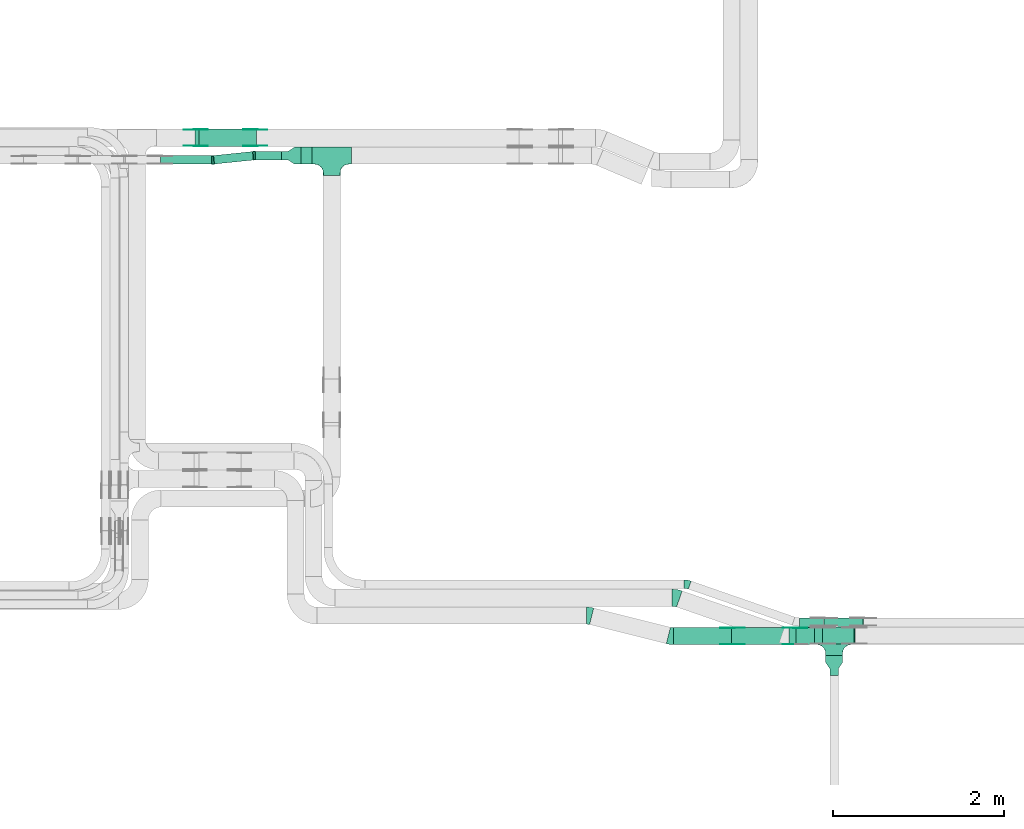
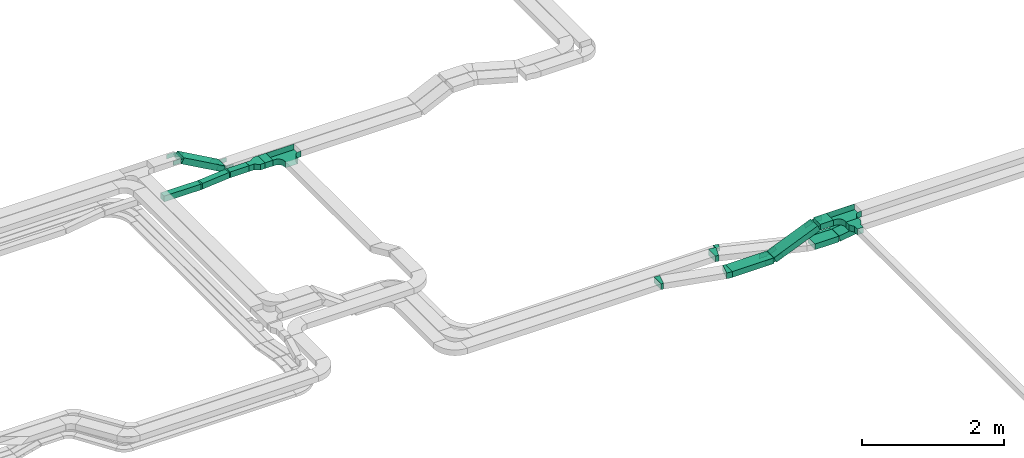
# One storey, part 13 of 23: 25 flow fittings, 12 flow segments.
"""IFC2X3 building model written with IfcOpenShell, lengths in millimetres."""

import ifcopenshell
import ifcopenshell.guid

model = None  # the IFC model being written
_history = None  # IfcOwnerHistory: only IFC2X3 demands one
_inside = {}  # id of a spatial element -> (the spatial element, [elements in it])
_under = {}  # id of a project, library or spatial element -> (it, [spatial elements below it])
_declared = {}  # id of a project -> (the project, [libraries it declares])
_typed = {}  # id of a type object -> (the type object, [elements of that type])
_made_of = {}  # id of a material, layer set ... -> (it, [elements and type objects made of it])


def new_model(schema):
    """Start an empty IFC model of exactly this schema.

    Asked for "IFC4X3", IfcOpenShell would pick the latest addendum, in which some entities
    have other attributes; the version numbers below select the first issue.
    IFC2X3 requires an IfcOwnerHistory on every rooted entity: one is made here for all.
    """
    global model, _history
    if schema == "IFC4X3":
        model = ifcopenshell.file(schema_version=(4, 3, 0, 0))
    else:
        model = ifcopenshell.file(schema=schema)
    _inside.clear()
    _under.clear()
    _declared.clear()
    _typed.clear()
    _made_of.clear()
    _history = None
    if model.schema == "IFC2X3":
        org = make("IfcOrganization", Name="unknown")
        user = make(
            "IfcPersonAndOrganization",
            ThePerson=make("IfcPerson", FamilyName="unknown"),
            TheOrganization=org,
        )
        app = make(
            "IfcApplication",
            ApplicationDeveloper=org,
            Version="unknown",
            ApplicationFullName="unknown",
            ApplicationIdentifier="unknown",
        )
        _history = make(
            "IfcOwnerHistory",
            OwningUser=user,
            OwningApplication=app,
            ChangeAction="ADDED",
            CreationDate=0,
        )
    return model


def make(cls, **values):
    """One entity of the class cls with the attributes given. An attribute that is None is left unset."""
    return model.create_entity(
        cls, **{name: value for name, value in values.items() if value is not None}
    )


def entity(cls, *values):
    """Any entity or typed value of the class cls, its attributes in the order of the schema. None: left unset."""
    e = model.create_entity(cls)
    for i, value in enumerate(values):
        if value is not None:
            e[i] = value
    return e


def rooted(cls, **values):
    """An entity with a GlobalId (a new one), such as an element, a storey or a relation."""
    return make(cls, GlobalId=ifcopenshell.guid.new(), OwnerHistory=_history, **values)


def si_unit(unit_type, name, prefix=None):
    """IfcSIUnit, for example si_unit("LENGTHUNIT", "METRE", prefix="MILLI")."""
    return make("IfcSIUnit", UnitType=unit_type, Prefix=prefix, Name=name)


def converted_unit(unit_type, name, factor, base, dimensions=None, offset=None):
    """IfcConversionBasedUnit, such as the inch: factor (a typed value) times the base unit."""
    return make(
        "IfcConversionBasedUnit"
        if offset is None
        else "IfcConversionBasedUnitWithOffset",
        ConversionOffset=offset,
        Dimensions=None
        if dimensions is None
        else entity("IfcDimensionalExponents", *dimensions),
        UnitType=unit_type,
        Name=name,
        ConversionFactor=make(
            "IfcMeasureWithUnit", ValueComponent=factor, UnitComponent=base
        ),
    )


def derived_unit(unit_type, elements):
    """IfcDerivedUnit: a product of units, each with its exponent."""
    return make(
        "IfcDerivedUnit",
        Elements=[
            make("IfcDerivedUnitElement", Unit=unit, Exponent=power)
            for unit, power in elements
        ],
        UnitType=unit_type,
    )


def assignment(units):
    """IfcUnitAssignment: the units of a project."""
    return None if units is None else make("IfcUnitAssignment", Units=units)


def point(xyz):
    """IfcCartesianPoint."""
    return None if xyz is None else make("IfcCartesianPoint", Coordinates=xyz)


def direction(xyz):
    """IfcDirection."""
    return None if xyz is None else make("IfcDirection", DirectionRatios=xyz)


def frame(location, z_axis=None, x_axis=None):
    """IfcAxis2Placement3D, a coordinate frame: its origin and axes. An axis left out is left unset."""
    return make(
        "IfcAxis2Placement3D",
        Location=point(location),
        Axis=direction(z_axis),
        RefDirection=direction(x_axis),
    )


def frame_2d(location, x_axis=None):
    """IfcAxis2Placement2D, a coordinate frame in the plane: its origin and x axis."""
    return make(
        "IfcAxis2Placement2D", Location=point(location), RefDirection=direction(x_axis)
    )


def origin():
    """The frame at (0, 0, 0) with its axes left unset."""
    return frame((0.0, 0.0, 0.0))


def origin_2d_with_axis():
    """The frame at (0, 0) in the plane with the x axis (1, 0) written out."""
    return frame_2d((0.0, 0.0), x_axis=(1.0, 0.0))


def place(relative_to, where):
    """IfcLocalPlacement: puts the frame where relative to a parent placement (None: the world)."""
    return make(
        "IfcLocalPlacement", PlacementRelTo=relative_to, RelativePlacement=where
    )


def context(
    kind, dimensions, precision=None, world=None, true_north=None, identifier=None
):
    """IfcGeometricRepresentationContext, for example the 3D "Model" context."""
    return make(
        "IfcGeometricRepresentationContext",
        ContextIdentifier=identifier,
        ContextType=kind,
        CoordinateSpaceDimension=dimensions,
        Precision=precision,
        WorldCoordinateSystem=world,
        TrueNorth=true_north,
    )


def subcontext(parent, identifier, kind, view, scale=None):
    """IfcGeometricRepresentationSubContext, for example "Body" below "Model"."""
    return make(
        "IfcGeometricRepresentationSubContext",
        ContextIdentifier=identifier,
        ContextType=kind,
        ParentContext=parent,
        TargetScale=scale,
        TargetView=view,
    )


def project(units=None, contexts=None):
    """IfcProject with its units and contexts."""
    return rooted(
        "IfcProject",
        Name="project",
        RepresentationContexts=contexts,
        UnitsInContext=assignment(units),
    )


def spatial(cls, under=None, at=None, **own):
    """A site, building, storey or space (cls), placed at a placement, below another one or the project."""
    s = rooted(cls, ObjectPlacement=at, **own)
    if under is not None:
        _under.setdefault(under.id(), (under, []))[1].append(s)
    return s


def polyline(points):
    """IfcPolyline through the points."""
    return make("IfcPolyline", Points=[point(p) for p in points])


def circle_curve(where, radius):
    """IfcCircle in the frame where."""
    return make("IfcCircle", Position=where, Radius=radius)


def parameter(value):
    """IfcParameterValue: where a trimmed curve begins or ends, as a parameter of its basis curve."""
    return model.create_entity("IfcParameterValue", value)


def trimmed(basis, trim1, trim2, sense, master):
    """IfcTrimmedCurve: the piece of a basis curve between two trims."""
    return make(
        "IfcTrimmedCurve",
        BasisCurve=basis,
        Trim1=trim1,
        Trim2=trim2,
        SenseAgreement=sense,
        MasterRepresentation=master,
    )


def segment(curve, same_sense, transition):
    """IfcCompositeCurveSegment."""
    return make(
        "IfcCompositeCurveSegment",
        Transition=transition,
        SameSense=same_sense,
        ParentCurve=curve,
    )


def composite_curve(segments, self_intersect=None):
    """IfcCompositeCurve: segments joined end to end."""
    return make("IfcCompositeCurve", Segments=segments, SelfIntersect=self_intersect)


def profile(cls, at=None, kind="AREA", **sizes):
    """A parametric profile (cls). Its sizes go by their IFC names, for example OverallWidth=200.0."""
    return make(cls, ProfileType=kind, Position=at, **sizes)


def rectangle(**sizes):
    """IfcRectangleProfileDef."""
    return profile("IfcRectangleProfileDef", **sizes)


def outline(outer, holes=None, kind="AREA"):
    """IfcArbitraryClosedProfileDef: a profile drawn as a closed curve; with holes, ...WithVoids."""
    if holes is None:
        return make("IfcArbitraryClosedProfileDef", ProfileType=kind, OuterCurve=outer)
    return make(
        "IfcArbitraryProfileDefWithVoids",
        ProfileType=kind,
        OuterCurve=outer,
        InnerCurves=holes,
    )


def extrude(swept, where, along, depth):
    """IfcExtrudedAreaSolid: the profile swept, set in the frame where, extruded along a direction by depth."""
    return make(
        "IfcExtrudedAreaSolid",
        SweptArea=swept,
        Position=where,
        ExtrudedDirection=direction(along),
        Depth=depth,
    )


def faces_of(points, faces, orient=None, outer=None):
    """IfcFace entities. A face is a list of loops; a loop is a list of indices into points, from 0.

    orient and outer hold one flag for each loop. By default every Orientation is true, the
    first loop of a face is its IfcFaceOuterBound and the others are IfcFaceBound.
    """
    made = []
    for i, loops in enumerate(faces):
        bounds = []
        for j, loop in enumerate(loops):
            is_outer = j == 0 if outer is None else outer[i][j]
            bounds.append(
                make(
                    "IfcFaceOuterBound" if is_outer else "IfcFaceBound",
                    Bound=make("IfcPolyLoop", Polygon=[points[k] for k in loop]),
                    Orientation=True if orient is None else orient[i][j],
                )
            )
        made.append(make("IfcFace", Bounds=bounds))
    return made


def faceted_brep(points, faces, orient=None, outer=None, voids=None):
    """IfcFacetedBrep: a solid bounded by flat faces; with voids (closed shells), ...WithVoids."""
    shared = [point(p) for p in points]
    hull = make("IfcClosedShell", CfsFaces=faces_of(shared, faces, orient, outer))
    if voids is None:
        return make("IfcFacetedBrep", Outer=hull)
    return make(
        "IfcFacetedBrepWithVoids",
        Outer=hull,
        Voids=[
            make(cls, CfsFaces=faces_of(shared, fs, o, b)) for cls, fs, o, b in voids
        ],
    )


def shape(context_of_items, identifier, shape_type, items):
    """IfcShapeRepresentation: the items that make up one representation, for example the "Body"."""
    return make(
        "IfcShapeRepresentation",
        ContextOfItems=context_of_items,
        RepresentationIdentifier=identifier,
        RepresentationType=shape_type,
        Items=items,
    )


def source(mapping_origin, context_of_items, identifier, shape_type, items):
    """IfcRepresentationMap: a shape defined once, which mapped items show again and again."""
    return make(
        "IfcRepresentationMap",
        MappingOrigin=mapping_origin,
        MappedRepresentation=shape(context_of_items, identifier, shape_type, items),
    )


def transform(
    local_origin,
    x_axis=None,
    y_axis=None,
    z_axis=None,
    scale=None,
    scale2=None,
    scale3=None,
    uniform=True,
):
    """IfcCartesianTransformationOperator3D, or its non-uniform kind. x_axis, y_axis, z_axis: its Axis1, 2, 3."""
    if uniform:
        return make(
            "IfcCartesianTransformationOperator3D",
            Axis1=direction(x_axis),
            Axis2=direction(y_axis),
            LocalOrigin=point(local_origin),
            Scale=scale,
            Axis3=direction(z_axis),
        )
    return make(
        "IfcCartesianTransformationOperator3DnonUniform",
        Axis1=direction(x_axis),
        Axis2=direction(y_axis),
        LocalOrigin=point(local_origin),
        Scale=scale,
        Axis3=direction(z_axis),
        Scale2=scale2,
        Scale3=scale3,
    )


def mapped(mapping_source, mapping_target):
    """IfcMappedItem: shows the shape of a source again, moved by a transform."""
    return make(
        "IfcMappedItem", MappingSource=mapping_source, MappingTarget=mapping_target
    )


def material(Name=None, Category=None):
    """IfcMaterial."""
    return make("IfcMaterial", Name=Name, Category=Category)


def made_of(thing, what):
    """Note that an element or type object is made of a material, layer set ...; save() writes the relation."""
    if what is not None:
        _made_of.setdefault(what.id(), (what, []))[1].append(thing)
    return thing


def type_object(cls, material=None, **own):
    """A type object (cls), such as IfcWallType, which elements share."""
    return made_of(rooted(cls, **own), material)


def type_shapes(of_type, sources):
    """Give a type object the sources (RepresentationMaps) that its elements show as mapped items."""
    of_type.RepresentationMaps = sources


def element(
    cls,
    number,
    at=None,
    inside=None,
    cuts=None,
    type_object=None,
    material=None,
    context=None,
    identifier="Body",
    shape_type=None,
    held_by="IfcProductDefinitionShape",
    body=None,
    shapes=None,
    **own,
):
    """One element of the class cls, such as IfcWall. Its Tag is "e" and its number.

    at: its placement. inside: the storey or other place that contains it. cuts: it is an
    opening in that element (IfcRelVoidsElement). A single representation is given by context,
    identifier, shape_type and body (its items); several are given by shapes. held_by: the class
    of the entity that holds the representations. save() writes the other relations.
    """
    e = rooted(cls, Tag="e%d" % number, ObjectPlacement=at, **own)
    if body is not None:
        shapes = [shape(context, identifier, shape_type, body)]
    if shapes is not None:
        e.Representation = make(held_by, Representations=shapes)
    if inside is not None:
        _inside.setdefault(inside.id(), (inside, []))[1].append(e)
    if cuts is not None:
        rooted(
            "IfcRelVoidsElement", RelatingBuildingElement=cuts, RelatedOpeningElement=e
        )
    if type_object is not None:
        _typed.setdefault(type_object.id(), (type_object, []))[1].append(e)
    return made_of(e, material)


def aggregate(whole, parts):
    """IfcRelAggregates: a whole, such as a stair, and the parts it consists of."""
    return rooted("IfcRelAggregates", RelatingObject=whole, RelatedObjects=parts)


def save(model, path):
    """Write the relations noted so far, then the file.

    IfcRelAggregates (storeys below a building ...), IfcRelContainedInSpatialStructure (elements
    in a storey), IfcRelDefinesByType, IfcRelAssociatesMaterial and IfcRelDeclares: one each for
    every whole, place, type object, material and project.
    """
    for whole, parts in _under.values():
        aggregate(whole, parts)
    for where, things in _inside.values():
        rooted(
            "IfcRelContainedInSpatialStructure",
            RelatedElements=things,
            RelatingStructure=where,
        )
    for kind, things in _typed.values():
        rooted("IfcRelDefinesByType", RelatedObjects=things, RelatingType=kind)
    for what, things in _made_of.values():
        rooted("IfcRelAssociatesMaterial", RelatedObjects=things, RelatingMaterial=what)
    for by, libraries in _declared.values():
        rooted("IfcRelDeclares", RelatingContext=by, RelatedDefinitions=libraries)
    model.write(path)


model = new_model("IFC2X3")

# Units and contexts
model_context = context("Model", 3, precision=0.01, world=origin(), true_north=direction((6.12303176911189e-17, 1.0)))
body_context = subcontext(model_context, "Body", "Model", "MODEL_VIEW")
ifc_project = project(units=[si_unit("LENGTHUNIT", "METRE", prefix="MILLI"), si_unit("AREAUNIT", "SQUARE_METRE"), si_unit("VOLUMEUNIT", "CUBIC_METRE"), converted_unit("PLANEANGLEUNIT", "DEGREE", entity("IfcRatioMeasure", 0.0174532925199433), si_unit("PLANEANGLEUNIT", "RADIAN"), dimensions=[0, 0, 0, 0, 0, 0, 0]), si_unit("MASSUNIT", "GRAM", prefix="KILO"), derived_unit("MASSDENSITYUNIT", [(si_unit("MASSUNIT", "GRAM", prefix="KILO"), 1), (si_unit("LENGTHUNIT", "METRE"), -3)]), derived_unit("MOMENTOFINERTIAUNIT", [(si_unit("LENGTHUNIT", "METRE"), 4)]), si_unit("TIMEUNIT", "SECOND"), si_unit("FREQUENCYUNIT", "HERTZ"), si_unit("THERMODYNAMICTEMPERATUREUNIT", "DEGREE_CELSIUS"), derived_unit("THERMALTRANSMITTANCEUNIT", [(si_unit("MASSUNIT", "GRAM", prefix="KILO"), 1), (si_unit("THERMODYNAMICTEMPERATUREUNIT", "KELVIN"), -1), (si_unit("TIMEUNIT", "SECOND"), -3)]), derived_unit("VOLUMETRICFLOWRATEUNIT", [(si_unit("LENGTHUNIT", "METRE"), 3), (si_unit("TIMEUNIT", "SECOND"), -1)]), derived_unit("MASSFLOWRATEUNIT", [(si_unit("MASSUNIT", "GRAM", prefix="KILO"), 1), (si_unit("TIMEUNIT", "SECOND"), -1)]), derived_unit("ROTATIONALFREQUENCYUNIT", [(si_unit("TIMEUNIT", "SECOND"), -1)]), si_unit("ELECTRICCURRENTUNIT", "AMPERE"), si_unit("ELECTRICVOLTAGEUNIT", "VOLT"), si_unit("POWERUNIT", "WATT"), si_unit("FORCEUNIT", "NEWTON", prefix="KILO"), si_unit("ILLUMINANCEUNIT", "LUX"), si_unit("LUMINOUSFLUXUNIT", "LUMEN"), si_unit("LUMINOUSINTENSITYUNIT", "CANDELA"), derived_unit("USERDEFINED", [(si_unit("MASSUNIT", "GRAM", prefix="KILO"), -1), (si_unit("LENGTHUNIT", "METRE"), -2), (si_unit("TIMEUNIT", "SECOND"), 3), (si_unit("LUMINOUSFLUXUNIT", "LUMEN"), 1)]), derived_unit("LINEARVELOCITYUNIT", [(si_unit("LENGTHUNIT", "METRE"), 1), (si_unit("TIMEUNIT", "SECOND"), -1)]), si_unit("PRESSUREUNIT", "PASCAL"), derived_unit("USERDEFINED", [(si_unit("LENGTHUNIT", "METRE"), -2), (si_unit("MASSUNIT", "GRAM", prefix="KILO"), 1), (si_unit("TIMEUNIT", "SECOND"), -2)]), derived_unit("LINEARFORCEUNIT", [(si_unit("MASSUNIT", "GRAM", prefix="KILO"), 1), (si_unit("LENGTHUNIT", "METRE"), 1), (si_unit("TIMEUNIT", "SECOND"), -2), (si_unit("LENGTHUNIT", "METRE"), -1)]), derived_unit("PLANARFORCEUNIT", [(si_unit("MASSUNIT", "GRAM", prefix="KILO"), 1), (si_unit("LENGTHUNIT", "METRE"), 1), (si_unit("TIMEUNIT", "SECOND"), -2), (si_unit("LENGTHUNIT", "METRE"), -2)])], contexts=[model_context])

# Site, building, storey
site_placement = place(None, origin())
site = spatial("IfcSite", under=ifc_project, at=site_placement, CompositionType="ELEMENT")
building_placement = place(site_placement, origin())
building = spatial("IfcBuilding", under=site, at=building_placement, CompositionType="ELEMENT")
storey_placement = place(building_placement, frame((0.0, 0.0, 24000.0)))
storey = spatial("IfcBuildingStorey", under=building, at=storey_placement, CompositionType="ELEMENT", Elevation=24000.0)

# Flow segments
cable_carrier_segment_type = type_object("IfcCableCarrierSegmentType", PredefinedType="CABLETRAYSEGMENT")
flow_segment_1_placement = place(storey_placement, frame((40980.88, 8734.99, 2970.0)))
element("IfcFlowSegment", 1, at=flow_segment_1_placement, inside=storey, type_object=cable_carrier_segment_type, context=body_context, shape_type="SweptSolid", body=[
    extrude(rectangle(XDim=214.228543290827, YDim=200.0, at=origin_2d_with_axis()), frame((107.11, 100.0, 0.0), z_axis=(0.0, 0.0, 1.0), x_axis=(-1.0, 0.0, 0.0)), (0.0, 0.0, 1.0), 100.000000000003),
])
flow_segment_2_placement = place(storey_placement, frame((35176.24, 14367.82, 2650.0)))
element("IfcFlowSegment", 2, at=flow_segment_2_placement, inside=storey, type_object=cable_carrier_segment_type, context=body_context, shape_type="SweptSolid", body=[
    extrude(rectangle(XDim=129.37484695584, YDim=199.999999999998, at=origin_2d_with_axis()), frame((64.69, 100.0, 0.0)), (0.0, 0.0, 1.0), 100.000000000003),
])
flow_segment_3_placement = place(storey_placement, frame((34637.54, 14417.82, 2650.0)))
element("IfcFlowSegment", 3, at=flow_segment_3_placement, inside=storey, type_object=cable_carrier_segment_type, context=body_context, shape_type="SweptSolid", body=[
    extrude(rectangle(XDim=308.701859648406, YDim=99.9999999999989, at=origin_2d_with_axis()), frame((154.35, 50.0, 0.0), z_axis=(0.0, 0.0, 1.0), x_axis=(-1.0, 0.0, 0.0)), (0.0, 0.0, 1.0), 100.000000000003),
])
flow_segment_4_placement = place(storey_placement, frame((39544.83, 8734.99, 2660.0)))
element("IfcFlowSegment", 4, at=flow_segment_4_placement, inside=storey, type_object=cable_carrier_segment_type, context=body_context, shape_type="SweptSolid", body=[
    extrude(rectangle(XDim=676.342218198149, YDim=200.0, at=origin_2d_with_axis()), frame((338.17, 100.0, 0.0)), (0.0, 0.0, 1.0), 100.000000000008),
])
flow_segment_5_placement = place(storey_placement, frame((40224.65, 8734.99, 2668.55)))
element("IfcFlowSegment", 5, at=flow_segment_5_placement, inside=storey, type_object=cable_carrier_segment_type, context=body_context, shape_type="SweptSolid", body=[
    extrude(rectangle(XDim=99.9999999999999, YDim=200.0, at=origin_2d_with_axis()), frame((19.41, 100.0, 46.08), z_axis=(0.921566974007608, 0.0, 0.388219412727468), x_axis=(-0.388219412727468, 0.0, 0.921566974007608)), (0.0, 0.0, 1.0), 774.697978791067),
])
flow_segment_6_placement = place(storey_placement, frame((40896.23, 8739.99, 2660.0)))
element("IfcFlowSegment", 6, at=flow_segment_6_placement, inside=storey, type_object=cable_carrier_segment_type, context=body_context, shape_type="SweptSolid", body=[
    extrude(rectangle(XDim=391.57439846643, YDim=200.0, at=origin_2d_with_axis()), frame((195.79, 100.0, 0.0), z_axis=(0.0, 0.0, 1.0), x_axis=(-1.0, 0.0, 0.0)), (0.0, 0.0, 1.0), 99.9999999999989),
])
flow_segment_7_placement = place(storey_placement, frame((41290.42, 8739.99, 2661.46)))
element("IfcFlowSegment", 7, at=flow_segment_7_placement, inside=storey, type_object=cable_carrier_segment_type, context=body_context, shape_type="SweptSolid", body=[
    extrude(rectangle(XDim=99.9999999999997, YDim=200.0, at=origin_2d_with_axis()), frame((7.88, 100.0, 49.37), z_axis=(0.987498754448712, 0.0, 0.157626805976146), x_axis=(-0.157626805976146, 0.0, 0.987498754448712)), (0.0, 0.0, 1.0), 370.080529813316),
])
flow_segment_8_placement = place(storey_placement, frame((41017.8, 8949.99, 2660.0)))
element("IfcFlowSegment", 8, at=flow_segment_8_placement, inside=storey, type_object=cable_carrier_segment_type, context=body_context, shape_type="SweptSolid", body=[
    extrude(rectangle(XDim=285.588978631639, YDim=99.9999999999989, at=origin_2d_with_axis()), frame((142.79, 50.0, 0.0), z_axis=(0.0, 0.0, 1.0), x_axis=(-1.0, 0.0, 0.0)), (0.0, 0.0, 1.0), 49.9999999999973),
])
flow_segment_9_placement = place(storey_placement, frame((41305.89, 8949.99, 2660.58)))
element("IfcFlowSegment", 9, at=flow_segment_9_placement, inside=storey, type_object=cable_carrier_segment_type, context=body_context, shape_type="SweptSolid", body=[
    extrude(rectangle(XDim=50.0000000000049, YDim=99.9999999999989, at=frame_2d((0.0, 0.0), x_axis=(0.0, 1.0))), frame((3.21, 50.0, 24.79), z_axis=(0.991697353687332, 0.0, 0.128593773914383), x_axis=(0.0, 1.0, 0.0)), (0.0, 0.0, 1.0), 460.840810267681),
])
flow_segment_10_placement = place(storey_placement, frame((33528.94, 14367.82, 2650.0)))
element("IfcFlowSegment", 10, at=flow_segment_10_placement, inside=storey, type_object=cable_carrier_segment_type, context=body_context, shape_type="SweptSolid", body=[
    extrude(rectangle(XDim=601.769552047414, YDim=99.9999999999989, at=origin_2d_with_axis()), frame((300.88, 50.0, 0.0)), (0.0, 0.0, 1.0), 100.000000000003),
])
flow_segment_11_placement = place(storey_placement, frame((34148.11, 14369.25, 2650.0)))
element("IfcFlowSegment", 11, at=flow_segment_11_placement, inside=storey, type_object=cable_carrier_segment_type, context=body_context, shape_type="SweptSolid", body=[
    extrude(rectangle(XDim=464.215540721123, YDim=100.000000000002, at=origin_2d_with_axis()), frame((236.02, 73.58, 0.0), z_axis=(0.0, 0.0, 1.0), x_axis=(-0.994711436792197, -0.102709091685221, 0.0)), (0.0, 0.0, 1.0), 100.000000000003),
])
flow_segment_12_placement = place(storey_placement, frame((33931.84, 14577.82, 2663.71)))
element("IfcFlowSegment", 12, at=flow_segment_12_placement, inside=storey, type_object=cable_carrier_segment_type, context=body_context, shape_type="SweptSolid", body=[
    extrude(rectangle(XDim=100.000000000003, YDim=200.000000000002, at=origin_2d_with_axis()), frame((24.4, 100.0, 418.93), z_axis=(0.872835715211419, 0.0, -0.488014153740823), x_axis=(0.488014153740823, 0.0, 0.872835715211419)), (0.0, 0.0, 1.0), 769.01505019583),
])

# Flow fittings
ifc_material_1 = material()
cable_carrier_fitting_type_1 = type_object("IfcCableCarrierFittingType", PredefinedType="NOTDEFINED", material=ifc_material_1)
shared_shape_1 = source(origin(), body_context, "Body", "SweptSolid", [
    extrude(outline(polyline([(-115.0, -100.0), (-38.33, -100.0), (38.33, -50.0), (115.0, -50.0), (115.0, 50.0), (38.33, 50.0), (-38.33, 100.0), (-115.0, 100.0), (-115.0, -100.0)])), frame((115.0, 0.0, -50.0)), (0.0, 0.0, 1.0), 100.0),
])
type_shapes(cable_carrier_fitting_type_1, [shared_shape_1])
flow_fitting_1_placement = place(storey_placement, frame((41425.11, 8604.99, 3020.0), z_axis=(0.0, 0.0, 1.0), x_axis=(0.0, -1.0, 0.0)))
element("IfcFlowFitting", 13, at=flow_fitting_1_placement, inside=storey, type_object=cable_carrier_fitting_type_1, material=ifc_material_1, Name="470_DKC_S5_adapter", context=body_context, shape_type="MappedRepresentation", body=[
    mapped(shared_shape_1, transform((0.0, 0.0, 0.0), scale=1.0)),
])
cable_carrier_fitting_type_2 = type_object("IfcCableCarrierFittingType", PredefinedType="NOTDEFINED", material=ifc_material_1)
shared_shape_2 = source(origin(), body_context, "Body", "SweptSolid", [
    extrude(outline(polyline([(-115.0, 50.0), (-115.0, -50.0), (-38.33, -50.0), (38.33, -100.0), (115.0, -100.0), (115.0, 100.0), (38.33, 100.0), (-38.33, 50.0), (-115.0, 50.0)])), frame((115.0, 0.0, -50.0), z_axis=(0.0, 0.0, -1.0), x_axis=(1.0, 0.0, 0.0)), (0.0, 0.0, -1.0), 100.0),
])
type_shapes(cable_carrier_fitting_type_2, [shared_shape_2])
flow_fitting_2_placement = place(storey_placement, frame((34946.24, 14467.82, 2700.0)))
element("IfcFlowFitting", 14, at=flow_fitting_2_placement, inside=storey, type_object=cable_carrier_fitting_type_2, material=ifc_material_1, Name="470_DKC_S5_adapter", context=body_context, shape_type="MappedRepresentation", body=[
    mapped(shared_shape_2, transform((0.0, 0.0, 0.0), scale=1.0)),
])
cable_carrier_fitting_type_3 = type_object("IfcCableCarrierFittingType", PredefinedType="NOTDEFINED", material=ifc_material_1)
shared_shape_3 = source(origin(), body_context, "Body", "Brep", [
    faceted_brep([(-103.41, -174.12, 50.0), (-100.0, -200.0, 50.0), (-100.0, -230.0, 50.0), (-99.2, -230.0, 50.0), (-99.2, -200.0, 50.0), (-102.63, -173.91, 50.0), (-112.7, -149.6, 50.0), (-128.72, -128.72, 50.0), (-149.6, -112.7, 50.0), (-173.91, -102.63, 50.0), (-200.0, -99.2, 50.0), (-230.0, -99.2, 50.0), (-230.0, -100.0, 50.0), (-200.0, -100.0, 50.0), (-174.12, -103.41, 50.0), (-150.0, -113.4, 50.0), (-129.29, -129.29, 50.0), (-113.4, -150.0, 50.0), (230.0, -100.0, 50.0), (230.0, -99.2, 50.0), (200.0, -99.2, 50.0), (173.91, -102.63, 50.0), (149.6, -112.7, 50.0), (128.72, -128.72, 50.0), (112.7, -149.6, 50.0), (102.63, -173.91, 50.0), (99.2, -200.0, 50.0), (99.2, -230.0, 50.0), (100.0, -230.0, 50.0), (100.0, -200.0, 50.0), (103.41, -174.12, 50.0), (113.4, -150.0, 50.0), (129.29, -129.29, 50.0), (150.0, -113.4, 50.0), (174.12, -103.41, 50.0), (200.0, -100.0, 50.0), (230.0, 99.2, 50.0), (230.0, 100.0, 50.0), (-230.0, 100.0, 50.0), (-230.0, 99.2, 50.0), (-230.0, -100.0, -50.0), (-230.0, 100.0, -50.0), (230.0, 100.0, -50.0), (230.0, -100.0, -50.0), (200.0, -100.0, -50.0), (174.12, -103.41, -50.0), (150.0, -113.4, -50.0), (129.29, -129.29, -50.0), (113.4, -150.0, -50.0), (103.41, -174.12, -50.0), (100.0, -200.0, -50.0), (100.0, -230.0, -50.0), (-100.0, -230.0, -50.0), (-100.0, -200.0, -50.0), (-103.41, -174.12, -50.0), (-113.4, -150.0, -50.0), (-129.29, -129.29, -50.0), (-150.0, -113.4, -50.0), (-174.12, -103.41, -50.0), (-200.0, -100.0, -50.0), (-100.0, -200.0, -49.2), (99.2, -230.0, -49.2), (-99.2, -230.0, -49.2), (-99.2, -200.0, -49.2), (-200.0, -99.2, -49.2), (-230.0, -99.2, -49.2), (230.0, -99.2, -49.2), (200.0, -99.2, -49.2), (-230.0, 99.2, -49.2), (-200.0, -100.0, -49.2), (200.0, -100.0, -49.2), (230.0, 99.2, -49.2), (99.2, -200.0, -49.2), (100.0, -200.0, -49.2), (-173.91, -102.63, -49.2), (-149.6, -112.7, -49.2), (-128.72, -128.72, -49.2), (-112.7, -149.6, -49.2), (-102.63, -173.91, -49.2), (102.63, -173.91, -49.2), (112.7, -149.6, -49.2), (128.72, -128.72, -49.2), (149.6, -112.7, -49.2), (173.91, -102.63, -49.2)], [[[0, 1, 2, 3, 4, 5, 6, 7, 8, 9, 10, 11, 12, 13, 14, 15, 16, 17]], [[18, 19, 20, 21, 22, 23, 24, 25, 26, 27, 28, 29, 30, 31, 32, 33, 34, 35]], [[36, 37, 38, 39]], [[40, 41, 42, 43, 44, 45, 46, 47, 48, 49, 50, 51, 52, 53, 54, 55, 56, 57, 58, 59]], [[2, 1, 60, 53, 52]], [[3, 2, 52, 51, 28, 27, 61, 62]], [[4, 3, 62, 63]], [[11, 10, 64, 65]], [[20, 19, 66, 67]], [[39, 38, 41, 40, 12, 11, 65, 68]], [[13, 12, 40, 59, 69]], [[18, 35, 70, 44, 43]], [[19, 18, 43, 42, 37, 36, 71, 66]], [[27, 26, 72, 61]], [[29, 28, 51, 50, 73]], [[38, 37, 42, 41]], [[36, 39, 68, 71]], [[68, 65, 64, 74, 75, 76, 77, 78, 63, 62, 61, 72, 79, 80, 81, 82, 83, 67, 66, 71]], [[14, 13, 69, 59, 58]], [[15, 14, 58, 57]], [[57, 56, 16, 15]], [[17, 16, 56, 55]], [[0, 17, 55, 54]], [[1, 0, 54, 53, 60]], [[5, 78, 77, 6]], [[6, 77, 76, 7]], [[63, 78, 5, 4]], [[8, 75, 74, 9]], [[9, 74, 64, 10]], [[7, 76, 75, 8]], [[21, 83, 82, 22]], [[22, 82, 81, 23]], [[67, 83, 21, 20]], [[24, 80, 79, 25]], [[25, 79, 72, 26]], [[23, 81, 80, 24]], [[30, 29, 73, 50, 49]], [[31, 30, 49, 48]], [[32, 31, 48, 47]], [[34, 33, 46, 45]], [[34, 45, 44, 70, 35]], [[46, 33, 32, 47]]]),
])
type_shapes(cable_carrier_fitting_type_3, [shared_shape_3])
for number, where, name in (
    (15, (35535.62, 14467.82, 2700.0), "470_DKC_S5_T"),
    (16, (41425.11, 8834.99, 3020.0), "470_DKC_S5_T"),
):
    element("IfcFlowFitting", number, at=place(storey_placement, frame(where)), inside=storey, type_object=cable_carrier_fitting_type_3, material=ifc_material_1, Name=name, context=body_context, shape_type="MappedRepresentation", body=[
        mapped(shared_shape_3, transform((0.0, 0.0, 0.0), scale=1.0)),
    ])
ifc_material_2 = material(Name="G")
cable_carrier_fitting_type_4 = type_object("IfcCableCarrierFittingType", PredefinedType="NOTDEFINED", material=ifc_material_2)
shared_shape_4 = source(origin(), body_context, "Body", "SweptSolid", [
    extrude(outline(composite_curve([segment(trimmed(circle_curve(frame_2d((-41.47, 0.0), x_axis=(1.0, 0.0)), 25.0), [parameter(90.0000000000007)], [parameter(270.0)], True, "PARAMETER"), True, "CONTINUOUS"), segment(polyline([(-41.47, -25.0), (-29.97, -25.0)]), True, "CONTINUOUS"), segment(polyline([(-29.97, -25.0), (-28.1, -38.5)]), True, "CONTINUOUS"), segment(polyline([(-28.1, -38.5), (99.53, -38.5)]), True, "CONTINUOUS"), segment(polyline([(99.53, -38.5), (99.53, 38.5)]), True, "CONTINUOUS"), segment(polyline([(99.53, 38.5), (-28.1, 38.5)]), True, "CONTINUOUS"), segment(polyline([(-28.1, 38.5), (-29.97, 25.0)]), True, "CONTINUOUS"), segment(polyline([(-29.97, 25.0), (-41.47, 25.0)]), True, "CONTINUOUS")], self_intersect=False)), frame((41.47, 0.0, 0.0), z_axis=(0.0, 0.0, -1.0), x_axis=(1.0, 0.0, 0.0)), (0.0, 0.0, -1.0), 2.0),
])
type_shapes(cable_carrier_fitting_type_4, [shared_shape_4])
flow_fitting_3_placement = place(storey_placement, frame((40968.97, 8739.53, 3020.0), z_axis=(0.0, -1.0, 0.0), x_axis=(-0.921566974007647, 0.0, -0.388219412727376)))
element("IfcFlowFitting", 17, at=flow_fitting_3_placement, inside=storey, type_object=cable_carrier_fitting_type_4, material=ifc_material_2, context=body_context, shape_type="MappedRepresentation", body=[
    mapped(shared_shape_4, transform((0.0, 0.0, 0.0), scale=1.0)),
])
cable_carrier_fitting_type_5 = type_object("IfcCableCarrierFittingType", PredefinedType="NOTDEFINED", material=ifc_material_2)
type_shapes(cable_carrier_fitting_type_5, [shared_shape_4])
flow_fitting_4_placement = place(storey_placement, frame((40968.97, 8928.45, 3020.0), z_axis=(0.0, 1.0, 0.0), x_axis=(1.0, 0.0, 0.0)))
element("IfcFlowFitting", 18, at=flow_fitting_4_placement, inside=storey, type_object=cable_carrier_fitting_type_5, material=ifc_material_2, context=body_context, shape_type="MappedRepresentation", body=[
    mapped(shared_shape_4, transform((0.0, 0.0, 0.0), scale=1.0)),
])
flow_fitting_5_placement = place(storey_placement, frame((40233.08, 8739.53, 2710.0), z_axis=(0.0, -1.0, 0.0), x_axis=(0.921566974007647, 0.0, 0.388219412727376)))
element("IfcFlowFitting", 19, at=flow_fitting_5_placement, inside=storey, type_object=cable_carrier_fitting_type_4, material=ifc_material_2, context=body_context, shape_type="MappedRepresentation", body=[
    mapped(shared_shape_4, transform((0.0, 0.0, 0.0), scale=1.0)),
])
flow_fitting_6_placement = place(storey_placement, frame((40233.08, 8928.45, 2710.0), z_axis=(0.0, 1.0, 0.0), x_axis=(-1.0, 0.0, 0.0)))
element("IfcFlowFitting", 20, at=flow_fitting_6_placement, inside=storey, type_object=cable_carrier_fitting_type_5, material=ifc_material_2, context=body_context, shape_type="MappedRepresentation", body=[
    mapped(shared_shape_4, transform((0.0, 0.0, 0.0), scale=1.0)),
])
flow_fitting_7_placement = place(storey_placement, frame((34640.62, 14773.28, 2700.0), z_axis=(0.0, 1.0, 0.0), x_axis=(-0.872835715211393, 0.0, 0.488014153740868)))
element("IfcFlowFitting", 21, at=flow_fitting_7_placement, inside=storey, type_object=cable_carrier_fitting_type_4, material=ifc_material_2, context=body_context, shape_type="MappedRepresentation", body=[
    mapped(shared_shape_4, transform((0.0, 0.0, 0.0), scale=1.0)),
])
flow_fitting_8_placement = place(storey_placement, frame((34640.62, 14584.36, 2700.0), z_axis=(0.0, -1.0, 0.0), x_axis=(1.0, 0.0, 0.0)))
element("IfcFlowFitting", 22, at=flow_fitting_8_placement, inside=storey, type_object=cable_carrier_fitting_type_5, material=ifc_material_2, context=body_context, shape_type="MappedRepresentation", body=[
    mapped(shared_shape_4, transform((0.0, 0.0, 0.0), scale=1.0)),
])
flow_fitting_9_placement = place(storey_placement, frame((33943.08, 14773.28, 3090.0), z_axis=(0.0, 1.0, 0.0), x_axis=(0.872835715211393, 0.0, -0.488014153740868)))
element("IfcFlowFitting", 23, at=flow_fitting_9_placement, inside=storey, type_object=cable_carrier_fitting_type_4, material=ifc_material_2, context=body_context, shape_type="MappedRepresentation", body=[
    mapped(shared_shape_4, transform((0.0, 0.0, 0.0), scale=1.0)),
])
flow_fitting_10_placement = place(storey_placement, frame((33943.08, 14584.36, 3090.0), z_axis=(0.0, -1.0, 0.0), x_axis=(-1.0, 0.0, 0.0)))
element("IfcFlowFitting", 24, at=flow_fitting_10_placement, inside=storey, type_object=cable_carrier_fitting_type_5, material=ifc_material_2, context=body_context, shape_type="MappedRepresentation", body=[
    mapped(shared_shape_4, transform((0.0, 0.0, 0.0), scale=1.0)),
])
cable_carrier_fitting_type_6 = type_object("IfcCableCarrierFittingType", PredefinedType="NOTDEFINED", material=ifc_material_2)
shared_shape_5 = source(origin(), body_context, "Body", "SweptSolid", [
    extrude(outline(composite_curve([segment(trimmed(circle_curve(frame_2d((-41.47, 0.0), x_axis=(1.0, 0.0)), 25.0), [parameter(90.0000000000007)], [parameter(270.0)], True, "PARAMETER"), True, "CONTINUOUS"), segment(polyline([(-41.47, -25.0), (-29.97, -25.0)]), True, "CONTINUOUS"), segment(polyline([(-29.97, -25.0), (-28.1, -38.5)]), True, "CONTINUOUS"), segment(polyline([(-28.1, -38.5), (99.53, -38.5)]), True, "CONTINUOUS"), segment(polyline([(99.53, -38.5), (99.53, 38.5)]), True, "CONTINUOUS"), segment(polyline([(99.53, 38.5), (-28.1, 38.5)]), True, "CONTINUOUS"), segment(polyline([(-28.1, 38.5), (-29.97, 25.0)]), True, "CONTINUOUS"), segment(polyline([(-29.97, 25.0), (-41.47, 25.0)]), True, "CONTINUOUS")], self_intersect=False)), frame((41.47, 0.0, 0.0)), (0.0, 0.0, 1.0), 2.0),
])
type_shapes(cable_carrier_fitting_type_6, [shared_shape_5])
for number, where, z_axis, x_axis in (
    (25, (40968.97, 8930.45, 3020.0), (0.0, 1.0, 0.0), (-0.921566974007647, 0.0, -0.388219412727376)),
    (26, (40233.08, 8930.45, 2710.0), (0.0, 1.0, 0.0), (0.921566974007647, 0.0, 0.388219412727376)),
):
    element("IfcFlowFitting", number, at=place(storey_placement, frame(where, z_axis=z_axis, x_axis=x_axis)), inside=storey, type_object=cable_carrier_fitting_type_6, material=ifc_material_2, context=body_context, shape_type="MappedRepresentation", body=[
        mapped(shared_shape_5, transform((0.0, 0.0, 0.0), scale=1.0)),
    ])
cable_carrier_fitting_type_7 = type_object("IfcCableCarrierFittingType", PredefinedType="NOTDEFINED", material=ifc_material_2)
type_shapes(cable_carrier_fitting_type_7, [shared_shape_5])
flow_fitting_11_placement = place(storey_placement, frame((40233.08, 8741.53, 2710.0), z_axis=(0.0, -1.0, 0.0), x_axis=(-1.0, 0.0, 0.0)))
element("IfcFlowFitting", 27, at=flow_fitting_11_placement, inside=storey, type_object=cable_carrier_fitting_type_7, material=ifc_material_2, context=body_context, shape_type="MappedRepresentation", body=[
    mapped(shared_shape_5, transform((0.0, 0.0, 0.0), scale=1.0)),
])
flow_fitting_12_placement = place(storey_placement, frame((34640.62, 14582.36, 2700.0), z_axis=(0.0, -1.0, 0.0), x_axis=(-0.872835715211393, 0.0, 0.488014153740868)))
element("IfcFlowFitting", 28, at=flow_fitting_12_placement, inside=storey, type_object=cable_carrier_fitting_type_6, material=ifc_material_2, context=body_context, shape_type="MappedRepresentation", body=[
    mapped(shared_shape_5, transform((0.0, 0.0, 0.0), scale=1.0)),
])
flow_fitting_13_placement = place(storey_placement, frame((34640.62, 14771.28, 2700.0), z_axis=(0.0, 1.0, 0.0), x_axis=(1.0, 0.0, 0.0)))
element("IfcFlowFitting", 29, at=flow_fitting_13_placement, inside=storey, type_object=cable_carrier_fitting_type_7, material=ifc_material_2, context=body_context, shape_type="MappedRepresentation", body=[
    mapped(shared_shape_5, transform((0.0, 0.0, 0.0), scale=1.0)),
])
flow_fitting_14_placement = place(storey_placement, frame((33943.08, 14582.36, 3090.0), z_axis=(0.0, -1.0, 0.0), x_axis=(0.872835715211393, 0.0, -0.488014153740868)))
element("IfcFlowFitting", 30, at=flow_fitting_14_placement, inside=storey, type_object=cable_carrier_fitting_type_6, material=ifc_material_2, context=body_context, shape_type="MappedRepresentation", body=[
    mapped(shared_shape_5, transform((0.0, 0.0, 0.0), scale=1.0)),
])
flow_fitting_15_placement = place(storey_placement, frame((33943.08, 14771.28, 3090.0), z_axis=(0.0, 1.0, 0.0), x_axis=(-1.0, 0.0, 0.0)))
element("IfcFlowFitting", 31, at=flow_fitting_15_placement, inside=storey, type_object=cable_carrier_fitting_type_7, material=ifc_material_2, context=body_context, shape_type="MappedRepresentation", body=[
    mapped(shared_shape_5, transform((0.0, 0.0, 0.0), scale=1.0)),
])
cable_carrier_fitting_type_8 = type_object("IfcCableCarrierFittingType", Name="470_DKC_S5_Variable Angle Elbow 0-45:-", PredefinedType="NOTDEFINED", material=ifc_material_1)
shared_shape_6 = source(origin(), body_context, "Body", "SweptSolid", [
    extrude(outline(composite_curve([segment(polyline([(-11.27, -50.55), (-10.27, -50.55)]), True, "CONTINUOUS"), segment(trimmed(circle_curve(frame_2d((-10.27, 199.45), x_axis=(0.0, -1.0)), 250.0), [parameter(0.0)], [parameter(5.89519350767973)], True, "PARAMETER"), True, "CONTINUOUS"), segment(polyline([(15.41, -49.23), (16.4, -49.13)]), True, "CONTINUOUS"), segment(polyline([(16.4, -49.13), (6.13, 50.34)]), True, "CONTINUOUS"), segment(polyline([(6.13, 50.34), (5.14, 50.24)]), True, "CONTINUOUS"), segment(trimmed(circle_curve(frame_2d((-10.27, 199.45), x_axis=(0.0, -1.0)), 150.0), [parameter(0.0)], [parameter(5.89519350767973)], True, "PARAMETER"), False, "CONTINUOUS"), segment(polyline([(-10.27, 49.45), (-11.27, 49.45)]), True, "CONTINUOUS"), segment(polyline([(-11.27, 49.45), (-11.27, -50.55)]), True, "CONTINUOUS")], self_intersect=False)), frame((-0.03, 0.55, -50.0)), (0.0, 0.0, 1.0), 100.0),
])
type_shapes(cable_carrier_fitting_type_8, [shared_shape_6])
flow_fitting_16_placement = place(storey_placement, frame((34626.24, 14467.82, 2700.0), z_axis=(0.0, 0.0, 1.0), x_axis=(-1.0, 0.0, 0.0)))
element("IfcFlowFitting", 32, at=flow_fitting_16_placement, inside=storey, type_object=cable_carrier_fitting_type_8, material=ifc_material_1, Name="470_DKC_S5_Variable Angle Elbow 0-45:-", ObjectType="470_DKC_S5_Variable Angle Elbow 0-45:-", context=body_context, shape_type="MappedRepresentation", body=[
    mapped(shared_shape_6, transform((0.0, 0.0, 0.0), scale=1.0)),
])
flow_fitting_17_placement = place(storey_placement, frame((34142.0, 14417.82, 2700.0)))
element("IfcFlowFitting", 33, at=flow_fitting_17_placement, inside=storey, type_object=cable_carrier_fitting_type_8, material=ifc_material_1, Name="470_DKC_S5_Variable Angle Elbow 0-45:-", ObjectType="470_DKC_S5_Variable Angle Elbow 0-45:-", context=body_context, shape_type="MappedRepresentation", body=[
    mapped(shared_shape_6, transform((0.0, 0.0, 0.0), scale=1.0)),
])
cable_carrier_fitting_type_9 = type_object("IfcCableCarrierFittingType", Name="470_DKC_S5_Variable Angle Elbow 0-45:-", PredefinedType="NOTDEFINED", material=ifc_material_1)
shared_shape_7 = source(origin(), body_context, "Body", "SweptSolid", [
    extrude(outline(composite_curve([segment(polyline([(-31.28, -103.79), (-30.28, -103.79)]), True, "CONTINUOUS"), segment(trimmed(circle_curve(frame_2d((-30.28, 246.21), x_axis=(0.0, -1.0)), 350.0), [parameter(0.0)], [parameter(14.0234237419715)], True, "PARAMETER"), True, "CONTINUOUS"), segment(polyline([(54.53, -93.35), (55.5, -93.11)]), True, "CONTINUOUS"), segment(polyline([(55.5, -93.11), (7.04, 100.93)]), True, "CONTINUOUS"), segment(polyline([(7.04, 100.93), (6.07, 100.68)]), True, "CONTINUOUS"), segment(trimmed(circle_curve(frame_2d((-30.28, 246.21), x_axis=(0.0, -1.0)), 150.0), [parameter(0.0)], [parameter(14.0234237419715)], True, "PARAMETER"), False, "CONTINUOUS"), segment(polyline([(-30.28, 96.21), (-31.28, 96.21)]), True, "CONTINUOUS"), segment(polyline([(-31.28, 96.21), (-31.28, -103.79)]), True, "CONTINUOUS")], self_intersect=False)), frame((-0.47, 3.79, -50.0)), (0.0, 0.0, 1.0), 100.0),
])
type_shapes(cable_carrier_fitting_type_9, [shared_shape_7])
for number, where, z_axis, x_axis, name in (
    (34, (39513.08, 8834.99, 2710.0), (0.0, 0.0, 1.0), (0.970196742340567, -0.242318553048981, 0.0), "470_DKC_S5_Variable Angle Elbow 0-45:-"),
    (35, (38552.36, 9074.94, 2710.0), (0.0, 0.0, 1.0), (-0.970196742340565, 0.242318553048987, 0.0), "470_DKC_S5_Variable Angle Elbow 0-45:-"),
):
    element("IfcFlowFitting", number, at=place(storey_placement, frame(where, z_axis=z_axis, x_axis=x_axis)), inside=storey, type_object=cable_carrier_fitting_type_9, material=ifc_material_1, Name=name, ObjectType="470_DKC_S5_Variable Angle Elbow 0-45:-", context=body_context, shape_type="MappedRepresentation", body=[
        mapped(shared_shape_7, transform((0.0, 0.0, 0.0), scale=1.0)),
    ])
cable_carrier_fitting_type_10 = type_object("IfcCableCarrierFittingType", Name="470_DKC_S5_Variable Angle Elbow 0-45:-", PredefinedType="NOTDEFINED", material=ifc_material_1)
shared_shape_8 = source(origin(), body_context, "Body", "SweptSolid", [
    extrude(outline(composite_curve([segment(polyline([(-41.96, -106.99), (-40.96, -106.99)]), True, "CONTINUOUS"), segment(trimmed(circle_curve(frame_2d((-40.96, 243.01), x_axis=(0.0, -1.0)), 350.0), [parameter(0.0)], [parameter(19.136971841609)], True, "PARAMETER"), True, "CONTINUOUS"), segment(polyline([(73.78, -87.65), (74.72, -87.32)]), True, "CONTINUOUS"), segment(polyline([(74.72, -87.32), (9.15, 101.63)]), True, "CONTINUOUS"), segment(polyline([(9.15, 101.63), (8.21, 101.3)]), True, "CONTINUOUS"), segment(trimmed(circle_curve(frame_2d((-40.96, 243.01), x_axis=(0.0, -1.0)), 150.0), [parameter(0.0)], [parameter(19.136971841609)], True, "PARAMETER"), False, "CONTINUOUS"), segment(polyline([(-40.96, 93.01), (-41.96, 93.01)]), True, "CONTINUOUS"), segment(polyline([(-41.96, 93.01), (-41.96, -106.99)]), True, "CONTINUOUS")], self_intersect=False)), frame((-1.18, 6.99, -50.0)), (0.0, 0.0, 1.0), 100.0),
])
type_shapes(cable_carrier_fitting_type_10, [shared_shape_8])
flow_fitting_18_placement = place(storey_placement, frame((39570.81, 9284.94, 2710.0), z_axis=(0.0, 0.0, 1.0), x_axis=(-0.944737568154262, 0.327827587792687, 0.0)))
element("IfcFlowFitting", 36, at=flow_fitting_18_placement, inside=storey, type_object=cable_carrier_fitting_type_10, material=ifc_material_1, Name="470_DKC_S5_Variable Angle Elbow 0-45:-", ObjectType="470_DKC_S5_Variable Angle Elbow 0-45:-", context=body_context, shape_type="MappedRepresentation", body=[
    mapped(shared_shape_8, transform((0.0, 0.0, 0.0), scale=1.0)),
])
cable_carrier_fitting_type_11 = type_object("IfcCableCarrierFittingType", Name="470_DKC_S5_Variable Angle Elbow 0-45:-", PredefinedType="NOTDEFINED", material=ifc_material_1)
shared_shape_9 = source(origin(), body_context, "Body", "SweptSolid", [
    extrude(outline(composite_curve([segment(polyline([(-33.77, -55.61), (-32.77, -55.61)]), True, "CONTINUOUS"), segment(trimmed(circle_curve(frame_2d((-32.77, 194.39), x_axis=(0.0, -1.0)), 250.0), [parameter(0.0)], [parameter(19.1369718416102)], True, "PARAMETER"), True, "CONTINUOUS"), segment(polyline([(49.19, -41.79), (50.13, -41.46)]), True, "CONTINUOUS"), segment(polyline([(50.13, -41.46), (17.35, 53.01)]), True, "CONTINUOUS"), segment(polyline([(17.35, 53.01), (16.41, 52.68)]), True, "CONTINUOUS"), segment(trimmed(circle_curve(frame_2d((-32.77, 194.39), x_axis=(0.0, -1.0)), 150.0), [parameter(0.0)], [parameter(19.1369718416102)], True, "PARAMETER"), False, "CONTINUOUS"), segment(polyline([(-32.77, 44.39), (-33.77, 44.39)]), True, "CONTINUOUS"), segment(polyline([(-33.77, 44.39), (-33.77, -55.61)]), True, "CONTINUOUS")], self_intersect=False)), frame((-0.95, 5.61, -25.0)), (0.0, 0.0, 1.0), 50.0000000000001),
])
type_shapes(cable_carrier_fitting_type_11, [shared_shape_9])
flow_fitting_19_placement = place(storey_placement, frame((39700.81, 9444.94, 2685.0), z_axis=(0.0, 0.0, 1.0), x_axis=(-0.944737568154257, 0.327827587792701, 0.0)))
element("IfcFlowFitting", 37, at=flow_fitting_19_placement, inside=storey, type_object=cable_carrier_fitting_type_11, material=ifc_material_1, Name="470_DKC_S5_Variable Angle Elbow 0-45:-", ObjectType="470_DKC_S5_Variable Angle Elbow 0-45:-", context=body_context, shape_type="MappedRepresentation", body=[
    mapped(shared_shape_9, transform((0.0, 0.0, 0.0), scale=1.0)),
])

save(model, "model.ifc")
